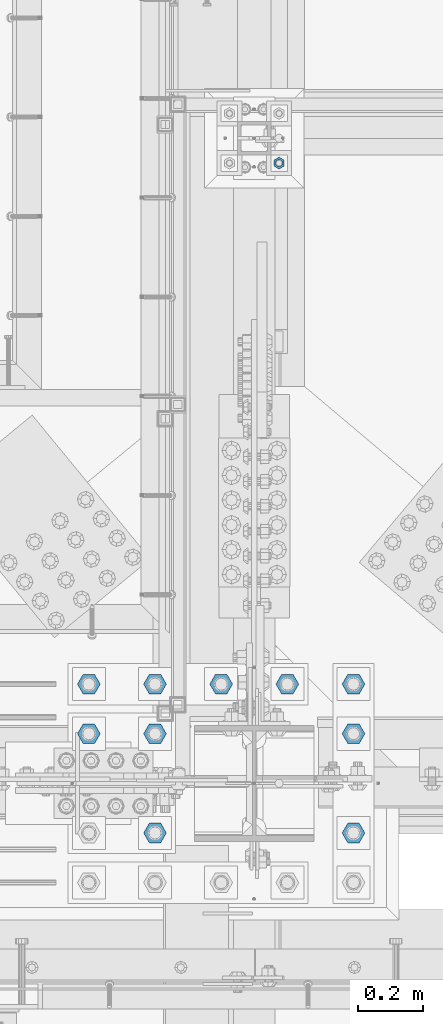
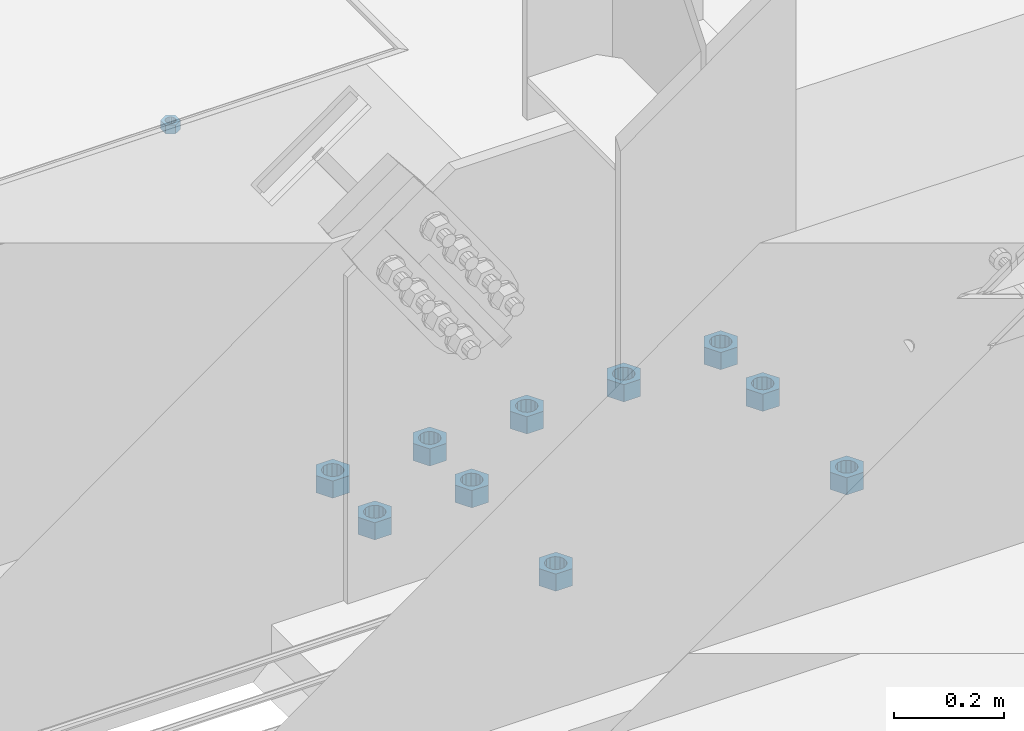
# One storey, part 1663 of 3843: 11 columns, 2 elements without a shape of their own.
"""IFC2X3 building model written with IfcOpenShell, lengths in millimetres."""

from ifc_helpers import new_model, si_unit, frame, origin_with_axes, place, context, subcontext, project, spatial, faceted_brep, material, type_object, element, aggregate, save


model = new_model("IFC2X3")

# Units and contexts
model_context = context("Model", 3, precision=1e-05, world=origin_with_axes())
body_context = subcontext(model_context, "Body", "Model", "MODEL_VIEW")
ifc_project = project(units=[si_unit("LENGTHUNIT", "METRE", prefix="MILLI"), si_unit("AREAUNIT", "SQUARE_METRE"), si_unit("VOLUMEUNIT", "CUBIC_METRE"), si_unit("MASSUNIT", "GRAM", prefix="KILO"), si_unit("TIMEUNIT", "SECOND"), si_unit("PLANEANGLEUNIT", "RADIAN"), si_unit("SOLIDANGLEUNIT", "STERADIAN"), si_unit("THERMODYNAMICTEMPERATUREUNIT", "DEGREE_CELSIUS"), si_unit("LUMINOUSINTENSITYUNIT", "LUMEN")], contexts=[model_context])

# Site, building, storey
site_placement = place(None, origin_with_axes())
site = spatial("IfcSite", under=ifc_project, at=site_placement, CompositionType="ELEMENT")
building_placement = place(site_placement, origin_with_axes())
building = spatial("IfcBuilding", under=site, at=building_placement, Name="Undefined", CompositionType="ELEMENT")
storey_placement = place(building_placement, origin_with_axes())
storey = spatial("IfcBuildingStorey", under=building, at=storey_placement, Name="Undefined", CompositionType="ELEMENT", Elevation=0.0)

# Assembly, column
assembly_1_placement = place(storey_placement, origin_with_axes())
assembly_1 = element("IfcElementAssembly", 1, at=assembly_1_placement, inside=storey, Name="TEMPLATE", AssemblyPlace="NOTDEFINED", PredefinedType="RIGID_FRAME")
ifc_material_1 = material(Name="STEEL/A36")
column_type_1 = type_object("IfcColumnType", Name="3/4_HEAVY_HEX_NUT", PredefinedType="NOTDEFINED")
column_1_placement = place(assembly_1_placement, frame((49072.8, 27520.9, 29330.65), z_axis=(1.0, 0.0, 0.0), x_axis=(0.0, 0.0, -1.0)))
column_1 = element("IfcColumn", 2, at=column_1_placement, type_object=column_type_1, material=ifc_material_1, Name="NUT", ObjectType="3/4_HEAVY_HEX_NUT", context=body_context, shape_type="Brep", body=[
    faceted_brep([(0.0, -18.2600002288818, 0.0), (0.0, -9.13000011444092, -15.8100004196167), (19.0500000000029, -9.13000011444092, -15.8100004196167), (19.0500000000029, -18.2600002288818, 0.0), (0.0, 9.13000011444092, -15.8100004196167), (19.0500000000029, 9.13000011444092, -15.8100004196167), (0.0, 18.2600002288818, 0.0), (19.0500000000029, 18.2600002288818, 0.0), (0.0, 9.13000011444092, 15.8100004196167), (19.0500000000029, 9.13000011444092, 15.8100004196167), (0.0, -9.13000011444092, 15.8100004196167), (19.0500000000029, -9.13000011444092, 15.8100004196167), (0.0, 0.0, 10.3199996948242), (0.0, 4.47768005527905, 9.29799844179797), (19.0500000000029, 4.47768005527905, 9.29799844179797), (19.0500000000029, 0.0, 10.3199996948242), (0.0, 8.06850066047627, 6.43441456490837), (19.0500000000029, 8.06850066047627, 6.43441456490837), (0.0, 10.0612557561908, 2.2964159705225), (19.0500000000029, 10.0612557561908, 2.2964159705225), (0.0, 10.0612557561908, -2.2964159705225), (19.0500000000029, 10.0612557561908, -2.2964159705225), (0.0, 8.06850066047627, -6.43441456490837), (19.0500000000029, 8.06850066047627, -6.43441456490837), (0.0, 4.47768005527905, -9.29799844179797), (19.0500000000029, 4.47768005527905, -9.29799844179797), (0.0, 0.0, -10.3199996948242), (19.0500000000029, 0.0, -10.3199996948242), (0.0, -4.47768005527905, -9.29799844179797), (19.0500000000029, -4.47768005527905, -9.29799844179797), (0.0, -8.06850066047627, -6.43441456490837), (19.0500000000029, -8.06850066047627, -6.43441456490837), (0.0, -10.0612557561908, -2.2964159705225), (19.0500000000029, -10.0612557561908, -2.2964159705225), (0.0, -10.0612557561908, 2.2964159705225), (19.0500000000029, -10.0612557561908, 2.2964159705225), (0.0, -8.06850066047627, 6.43441456490837), (19.0500000000029, -8.06850066047627, 6.43441456490837), (0.0, -4.47768005527905, 9.29799844179797), (19.0500000000029, -4.47768005527905, 9.29799844179797)], [[[0, 1, 2, 3]], [[1, 4, 5, 2]], [[4, 6, 7, 5]], [[6, 8, 9, 7]], [[8, 10, 11, 9]], [[10, 0, 3, 11]], [[12, 13, 14, 15]], [[13, 16, 17, 14]], [[16, 18, 19, 17]], [[18, 20, 21, 19]], [[20, 22, 23, 21]], [[22, 24, 25, 23]], [[24, 26, 27, 25]], [[26, 28, 29, 27]], [[28, 30, 31, 29]], [[30, 32, 33, 31]], [[32, 34, 35, 33]], [[34, 36, 37, 35]], [[36, 38, 39, 37]], [[38, 12, 15, 39]], [[5, 7, 9, 11, 3, 2], [17, 19, 21, 23, 25, 27, 29, 31, 33, 35, 37, 39, 15, 14]], [[10, 8, 6, 4, 1, 0], [38, 36, 34, 32, 30, 28, 26, 24, 22, 20, 18, 16, 13, 12]]]),
])
aggregate(assembly_1, [column_1])

# Assembly, columns
assembly_2_placement = place(storey_placement, origin_with_axes())
assembly_2 = element("IfcElementAssembly", 3, at=assembly_2_placement, inside=storey, Name="TEMPLATE", AssemblyPlace="NOTDEFINED", PredefinedType="RIGID_FRAME")
ifc_material_2 = material(Name="STEEL/A572-50")
column_type_2 = type_object("IfcColumnType", Name="1-1/2_HEAVY_HEX_NUT", PredefinedType="NOTDEFINED")
column_2_placement = place(assembly_2_placement, frame((48691.8, 25463.5, 29730.7), z_axis=(0.0, -1.0, 0.0), x_axis=(0.0, 0.0, -1.0)))
column_2 = element("IfcColumn", 4, at=column_2_placement, type_object=column_type_2, material=ifc_material_2, Name="NUT", ObjectType="1-1/2_HEAVY_HEX_NUT", context=body_context, shape_type="Brep", body=[
    faceted_brep([(0.0, -34.9199981689453, 0.0), (0.0, -17.4599990844727, -30.25), (38.0999999999985, -17.4599990844727, -30.25), (38.0999999999985, -34.9199981689453, 0.0), (0.0, 17.4599990844727, -30.25), (38.0999999999985, 17.4599990844727, -30.25), (0.0, 34.9199981689453, 0.0), (38.0999999999985, 34.9199981689453, 0.0), (0.0, 17.4599990844727, 30.25), (38.0999999999985, 17.4599990844727, 30.25), (0.0, -17.4599990844727, 30.25), (38.0999999999985, -17.4599990844727, 30.25), (0.0, 0.0, 20.6399993896484), (0.0, 8.9553601105581, 18.5959968835959), (38.0999999999985, 8.9553601105581, 18.5959968835959), (38.0999999999985, 0.0, 20.6399993896484), (0.0, 16.1370013209525, 12.8688291298167), (38.0999999999985, 16.1370013209525, 12.8688291298167), (0.0, 20.1225115123816, 4.59283194104501), (38.0999999999985, 20.1225115123816, 4.59283194104501), (0.0, 20.1225115123816, -4.59283194104501), (38.0999999999985, 20.1225115123816, -4.59283194104501), (0.0, 16.1370013209525, -12.8688291298167), (38.0999999999985, 16.1370013209525, -12.8688291298167), (0.0, 8.9553601105581, -18.5959968835959), (38.0999999999985, 8.9553601105581, -18.5959968835959), (0.0, 0.0, -20.6399993896484), (38.0999999999985, 0.0, -20.6399993896484), (0.0, -8.9553601105581, -18.5959968835959), (38.0999999999985, -8.9553601105581, -18.5959968835959), (0.0, -16.1370013209525, -12.8688291298167), (38.0999999999985, -16.1370013209525, -12.8688291298167), (0.0, -20.1225115123816, -4.59283194104501), (38.0999999999985, -20.1225115123816, -4.59283194104501), (0.0, -20.1225115123816, 4.59283194104501), (38.0999999999985, -20.1225115123816, 4.59283194104501), (0.0, -16.1370013209525, 12.8688291298167), (38.0999999999985, -16.1370013209525, 12.8688291298167), (0.0, -8.9553601105581, 18.5959968835959), (38.0999999999985, -8.9553601105581, 18.5959968835959)], [[[0, 1, 2, 3]], [[1, 4, 5, 2]], [[4, 6, 7, 5]], [[6, 8, 9, 7]], [[8, 10, 11, 9]], [[10, 0, 3, 11]], [[12, 13, 14, 15]], [[13, 16, 17, 14]], [[16, 18, 19, 17]], [[18, 20, 21, 19]], [[20, 22, 23, 21]], [[22, 24, 25, 23]], [[24, 26, 27, 25]], [[26, 28, 29, 27]], [[28, 30, 31, 29]], [[30, 32, 33, 31]], [[32, 34, 35, 33]], [[34, 36, 37, 35]], [[36, 38, 39, 37]], [[38, 12, 15, 39]], [[5, 7, 9, 11, 3, 2], [17, 19, 21, 23, 25, 27, 29, 31, 33, 35, 37, 39, 15, 14]], [[10, 8, 6, 4, 1, 0], [38, 36, 34, 32, 30, 28, 26, 24, 22, 20, 18, 16, 13, 12]]]),
])
column_3_placement = place(assembly_2_placement, frame((49301.4, 25463.5, 29730.7), z_axis=(0.0, 1.0, 0.0), x_axis=(0.0, 0.0, -1.0)))
column_3 = element("IfcColumn", 5, at=column_3_placement, type_object=column_type_2, material=ifc_material_2, Name="NUT", ObjectType="1-1/2_HEAVY_HEX_NUT", context=body_context, shape_type="Brep", body=[
    faceted_brep([(0.0, -34.9199981689453, 0.0), (0.0, -17.4599990844727, -30.25), (38.0999999999985, -17.4599990844727, -30.25), (38.0999999999985, -34.9199981689453, 0.0), (0.0, 17.4599990844727, -30.25), (38.0999999999985, 17.4599990844727, -30.25), (0.0, 34.9199981689453, 0.0), (38.0999999999985, 34.9199981689453, 0.0), (0.0, 17.4599990844727, 30.25), (38.0999999999985, 17.4599990844727, 30.25), (0.0, -17.4599990844727, 30.25), (38.0999999999985, -17.4599990844727, 30.25), (0.0, 0.0, 20.6399993896484), (0.0, 8.9553601105581, 18.5959968835959), (38.0999999999985, 8.9553601105581, 18.5959968835959), (38.0999999999985, 0.0, 20.6399993896484), (0.0, 16.1370013209525, 12.8688291298167), (38.0999999999985, 16.1370013209525, 12.8688291298167), (0.0, 20.1225115123816, 4.59283194104501), (38.0999999999985, 20.1225115123816, 4.59283194104501), (0.0, 20.1225115123816, -4.59283194104501), (38.0999999999985, 20.1225115123816, -4.59283194104501), (0.0, 16.1370013209525, -12.8688291298167), (38.0999999999985, 16.1370013209525, -12.8688291298167), (0.0, 8.9553601105581, -18.5959968835959), (38.0999999999985, 8.9553601105581, -18.5959968835959), (0.0, 0.0, -20.6399993896484), (38.0999999999985, 0.0, -20.6399993896484), (0.0, -8.9553601105581, -18.5959968835959), (38.0999999999985, -8.9553601105581, -18.5959968835959), (0.0, -16.1370013209525, -12.8688291298167), (38.0999999999985, -16.1370013209525, -12.8688291298167), (0.0, -20.1225115123816, -4.59283194104501), (38.0999999999985, -20.1225115123816, -4.59283194104501), (0.0, -20.1225115123816, 4.59283194104501), (38.0999999999985, -20.1225115123816, 4.59283194104501), (0.0, -16.1370013209525, 12.8688291298167), (38.0999999999985, -16.1370013209525, 12.8688291298167), (0.0, -8.9553601105581, 18.5959968835959), (38.0999999999985, -8.9553601105581, 18.5959968835959)], [[[0, 1, 2, 3]], [[1, 4, 5, 2]], [[4, 6, 7, 5]], [[6, 8, 9, 7]], [[8, 10, 11, 9]], [[10, 0, 3, 11]], [[12, 13, 14, 15]], [[13, 16, 17, 14]], [[16, 18, 19, 17]], [[18, 20, 21, 19]], [[20, 22, 23, 21]], [[22, 24, 25, 23]], [[24, 26, 27, 25]], [[26, 28, 29, 27]], [[28, 30, 31, 29]], [[30, 32, 33, 31]], [[32, 34, 35, 33]], [[34, 36, 37, 35]], [[36, 38, 39, 37]], [[38, 12, 15, 39]], [[5, 7, 9, 11, 3, 2], [17, 19, 21, 23, 25, 27, 29, 31, 33, 35, 37, 39, 15, 14]], [[10, 8, 6, 4, 1, 0], [38, 36, 34, 32, 30, 28, 26, 24, 22, 20, 18, 16, 13, 12]]]),
])
column_4_placement = place(assembly_2_placement, frame((48488.6, 25768.3, 29730.7), z_axis=(0.0, -1.0, 0.0), x_axis=(0.0, 0.0, -1.0)))
column_4 = element("IfcColumn", 6, at=column_4_placement, type_object=column_type_2, material=ifc_material_2, Name="NUT", ObjectType="1-1/2_HEAVY_HEX_NUT", context=body_context, shape_type="Brep", body=[
    faceted_brep([(0.0, -34.9199981689453, 0.0), (0.0, -17.4599990844727, -30.25), (38.0999999999985, -17.4599990844727, -30.25), (38.0999999999985, -34.9199981689453, 0.0), (0.0, 17.4599990844727, -30.25), (38.0999999999985, 17.4599990844727, -30.25), (0.0, 34.9199981689453, 0.0), (38.0999999999985, 34.9199981689453, 0.0), (0.0, 17.4599990844727, 30.25), (38.0999999999985, 17.4599990844727, 30.25), (0.0, -17.4599990844727, 30.25), (38.0999999999985, -17.4599990844727, 30.25), (0.0, 0.0, 20.6399993896484), (0.0, 8.9553601105581, 18.5959968835959), (38.0999999999985, 8.9553601105581, 18.5959968835959), (38.0999999999985, 0.0, 20.6399993896484), (0.0, 16.1370013209525, 12.8688291298167), (38.0999999999985, 16.1370013209525, 12.8688291298167), (0.0, 20.1225115123816, 4.59283194104501), (38.0999999999985, 20.1225115123816, 4.59283194104501), (0.0, 20.1225115123816, -4.59283194104501), (38.0999999999985, 20.1225115123816, -4.59283194104501), (0.0, 16.1370013209525, -12.8688291298167), (38.0999999999985, 16.1370013209525, -12.8688291298167), (0.0, 8.9553601105581, -18.5959968835959), (38.0999999999985, 8.9553601105581, -18.5959968835959), (0.0, 0.0, -20.6399993896484), (38.0999999999985, 0.0, -20.6399993896484), (0.0, -8.9553601105581, -18.5959968835959), (38.0999999999985, -8.9553601105581, -18.5959968835959), (0.0, -16.1370013209525, -12.8688291298167), (38.0999999999985, -16.1370013209525, -12.8688291298167), (0.0, -20.1225115123816, -4.59283194104501), (38.0999999999985, -20.1225115123816, -4.59283194104501), (0.0, -20.1225115123816, 4.59283194104501), (38.0999999999985, -20.1225115123816, 4.59283194104501), (0.0, -16.1370013209525, 12.8688291298167), (38.0999999999985, -16.1370013209525, 12.8688291298167), (0.0, -8.9553601105581, 18.5959968835959), (38.0999999999985, -8.9553601105581, 18.5959968835959)], [[[0, 1, 2, 3]], [[1, 4, 5, 2]], [[4, 6, 7, 5]], [[6, 8, 9, 7]], [[8, 10, 11, 9]], [[10, 0, 3, 11]], [[12, 13, 14, 15]], [[13, 16, 17, 14]], [[16, 18, 19, 17]], [[18, 20, 21, 19]], [[20, 22, 23, 21]], [[22, 24, 25, 23]], [[24, 26, 27, 25]], [[26, 28, 29, 27]], [[28, 30, 31, 29]], [[30, 32, 33, 31]], [[32, 34, 35, 33]], [[34, 36, 37, 35]], [[36, 38, 39, 37]], [[38, 12, 15, 39]], [[5, 7, 9, 11, 3, 2], [17, 19, 21, 23, 25, 27, 29, 31, 33, 35, 37, 39, 15, 14]], [[10, 8, 6, 4, 1, 0], [38, 36, 34, 32, 30, 28, 26, 24, 22, 20, 18, 16, 13, 12]]]),
])
column_5_placement = place(assembly_2_placement, frame((48691.8, 25768.3, 29730.7), z_axis=(0.0, -1.0, 0.0), x_axis=(0.0, 0.0, -1.0)))
column_5 = element("IfcColumn", 7, at=column_5_placement, type_object=column_type_2, material=ifc_material_2, Name="NUT", ObjectType="1-1/2_HEAVY_HEX_NUT", context=body_context, shape_type="Brep", body=[
    faceted_brep([(0.0, -34.9199981689453, 0.0), (0.0, -17.4599990844727, -30.25), (38.0999999999985, -17.4599990844727, -30.25), (38.0999999999985, -34.9199981689453, 0.0), (0.0, 17.4599990844727, -30.25), (38.0999999999985, 17.4599990844727, -30.25), (0.0, 34.9199981689453, 0.0), (38.0999999999985, 34.9199981689453, 0.0), (0.0, 17.4599990844727, 30.25), (38.0999999999985, 17.4599990844727, 30.25), (0.0, -17.4599990844727, 30.25), (38.0999999999985, -17.4599990844727, 30.25), (0.0, 0.0, 20.6399993896484), (0.0, 8.9553601105581, 18.5959968835959), (38.0999999999985, 8.9553601105581, 18.5959968835959), (38.0999999999985, 0.0, 20.6399993896484), (0.0, 16.1370013209525, 12.8688291298167), (38.0999999999985, 16.1370013209525, 12.8688291298167), (0.0, 20.1225115123816, 4.59283194104501), (38.0999999999985, 20.1225115123816, 4.59283194104501), (0.0, 20.1225115123816, -4.59283194104501), (38.0999999999985, 20.1225115123816, -4.59283194104501), (0.0, 16.1370013209525, -12.8688291298167), (38.0999999999985, 16.1370013209525, -12.8688291298167), (0.0, 8.9553601105581, -18.5959968835959), (38.0999999999985, 8.9553601105581, -18.5959968835959), (0.0, 0.0, -20.6399993896484), (38.0999999999985, 0.0, -20.6399993896484), (0.0, -8.9553601105581, -18.5959968835959), (38.0999999999985, -8.9553601105581, -18.5959968835959), (0.0, -16.1370013209525, -12.8688291298167), (38.0999999999985, -16.1370013209525, -12.8688291298167), (0.0, -20.1225115123816, -4.59283194104501), (38.0999999999985, -20.1225115123816, -4.59283194104501), (0.0, -20.1225115123816, 4.59283194104501), (38.0999999999985, -20.1225115123816, 4.59283194104501), (0.0, -16.1370013209525, 12.8688291298167), (38.0999999999985, -16.1370013209525, 12.8688291298167), (0.0, -8.9553601105581, 18.5959968835959), (38.0999999999985, -8.9553601105581, 18.5959968835959)], [[[0, 1, 2, 3]], [[1, 4, 5, 2]], [[4, 6, 7, 5]], [[6, 8, 9, 7]], [[8, 10, 11, 9]], [[10, 0, 3, 11]], [[12, 13, 14, 15]], [[13, 16, 17, 14]], [[16, 18, 19, 17]], [[18, 20, 21, 19]], [[20, 22, 23, 21]], [[22, 24, 25, 23]], [[24, 26, 27, 25]], [[26, 28, 29, 27]], [[28, 30, 31, 29]], [[30, 32, 33, 31]], [[32, 34, 35, 33]], [[34, 36, 37, 35]], [[36, 38, 39, 37]], [[38, 12, 15, 39]], [[5, 7, 9, 11, 3, 2], [17, 19, 21, 23, 25, 27, 29, 31, 33, 35, 37, 39, 15, 14]], [[10, 8, 6, 4, 1, 0], [38, 36, 34, 32, 30, 28, 26, 24, 22, 20, 18, 16, 13, 12]]]),
])
column_6_placement = place(assembly_2_placement, frame((49301.4, 25768.3, 29730.7), z_axis=(0.0, 1.0, 0.0), x_axis=(0.0, 0.0, -1.0)))
column_6 = element("IfcColumn", 8, at=column_6_placement, type_object=column_type_2, material=ifc_material_2, Name="NUT", ObjectType="1-1/2_HEAVY_HEX_NUT", context=body_context, shape_type="Brep", body=[
    faceted_brep([(0.0, -34.9199981689453, 0.0), (0.0, -17.4599990844727, -30.25), (38.0999999999985, -17.4599990844727, -30.25), (38.0999999999985, -34.9199981689453, 0.0), (0.0, 17.4599990844727, -30.25), (38.0999999999985, 17.4599990844727, -30.25), (0.0, 34.9199981689453, 0.0), (38.0999999999985, 34.9199981689453, 0.0), (0.0, 17.4599990844727, 30.25), (38.0999999999985, 17.4599990844727, 30.25), (0.0, -17.4599990844727, 30.25), (38.0999999999985, -17.4599990844727, 30.25), (0.0, 0.0, 20.6399993896484), (0.0, 8.9553601105581, 18.5959968835959), (38.0999999999985, 8.9553601105581, 18.5959968835959), (38.0999999999985, 0.0, 20.6399993896484), (0.0, 16.1370013209525, 12.8688291298167), (38.0999999999985, 16.1370013209525, 12.8688291298167), (0.0, 20.1225115123816, 4.59283194104501), (38.0999999999985, 20.1225115123816, 4.59283194104501), (0.0, 20.1225115123816, -4.59283194104501), (38.0999999999985, 20.1225115123816, -4.59283194104501), (0.0, 16.1370013209525, -12.8688291298167), (38.0999999999985, 16.1370013209525, -12.8688291298167), (0.0, 8.9553601105581, -18.5959968835959), (38.0999999999985, 8.9553601105581, -18.5959968835959), (0.0, 0.0, -20.6399993896484), (38.0999999999985, 0.0, -20.6399993896484), (0.0, -8.9553601105581, -18.5959968835959), (38.0999999999985, -8.9553601105581, -18.5959968835959), (0.0, -16.1370013209525, -12.8688291298167), (38.0999999999985, -16.1370013209525, -12.8688291298167), (0.0, -20.1225115123816, -4.59283194104501), (38.0999999999985, -20.1225115123816, -4.59283194104501), (0.0, -20.1225115123816, 4.59283194104501), (38.0999999999985, -20.1225115123816, 4.59283194104501), (0.0, -16.1370013209525, 12.8688291298167), (38.0999999999985, -16.1370013209525, 12.8688291298167), (0.0, -8.9553601105581, 18.5959968835959), (38.0999999999985, -8.9553601105581, 18.5959968835959)], [[[0, 1, 2, 3]], [[1, 4, 5, 2]], [[4, 6, 7, 5]], [[6, 8, 9, 7]], [[8, 10, 11, 9]], [[10, 0, 3, 11]], [[12, 13, 14, 15]], [[13, 16, 17, 14]], [[16, 18, 19, 17]], [[18, 20, 21, 19]], [[20, 22, 23, 21]], [[22, 24, 25, 23]], [[24, 26, 27, 25]], [[26, 28, 29, 27]], [[28, 30, 31, 29]], [[30, 32, 33, 31]], [[32, 34, 35, 33]], [[34, 36, 37, 35]], [[36, 38, 39, 37]], [[38, 12, 15, 39]], [[5, 7, 9, 11, 3, 2], [17, 19, 21, 23, 25, 27, 29, 31, 33, 35, 37, 39, 15, 14]], [[10, 8, 6, 4, 1, 0], [38, 36, 34, 32, 30, 28, 26, 24, 22, 20, 18, 16, 13, 12]]]),
])
column_7_placement = place(assembly_2_placement, frame((48488.6, 25920.7, 29730.7), z_axis=(0.0, -1.0, 0.0), x_axis=(0.0, 0.0, -1.0)))
column_7 = element("IfcColumn", 9, at=column_7_placement, type_object=column_type_2, material=ifc_material_2, Name="NUT", ObjectType="1-1/2_HEAVY_HEX_NUT", context=body_context, shape_type="Brep", body=[
    faceted_brep([(0.0, -34.9199981689453, 0.0), (0.0, -17.4599990844727, -30.25), (38.0999999999985, -17.4599990844727, -30.25), (38.0999999999985, -34.9199981689453, 0.0), (0.0, 17.4599990844727, -30.25), (38.0999999999985, 17.4599990844727, -30.25), (0.0, 34.9199981689453, 0.0), (38.0999999999985, 34.9199981689453, 0.0), (0.0, 17.4599990844727, 30.25), (38.0999999999985, 17.4599990844727, 30.25), (0.0, -17.4599990844727, 30.25), (38.0999999999985, -17.4599990844727, 30.25), (0.0, 0.0, 20.6399993896484), (0.0, 8.9553601105581, 18.5959968835959), (38.0999999999985, 8.9553601105581, 18.5959968835959), (38.0999999999985, 0.0, 20.6399993896484), (0.0, 16.1370013209525, 12.8688291298167), (38.0999999999985, 16.1370013209525, 12.8688291298167), (0.0, 20.1225115123816, 4.59283194104501), (38.0999999999985, 20.1225115123816, 4.59283194104501), (0.0, 20.1225115123816, -4.59283194104501), (38.0999999999985, 20.1225115123816, -4.59283194104501), (0.0, 16.1370013209525, -12.8688291298167), (38.0999999999985, 16.1370013209525, -12.8688291298167), (0.0, 8.9553601105581, -18.5959968835959), (38.0999999999985, 8.9553601105581, -18.5959968835959), (0.0, 0.0, -20.6399993896484), (38.0999999999985, 0.0, -20.6399993896484), (0.0, -8.9553601105581, -18.5959968835959), (38.0999999999985, -8.9553601105581, -18.5959968835959), (0.0, -16.1370013209525, -12.8688291298167), (38.0999999999985, -16.1370013209525, -12.8688291298167), (0.0, -20.1225115123816, -4.59283194104501), (38.0999999999985, -20.1225115123816, -4.59283194104501), (0.0, -20.1225115123816, 4.59283194104501), (38.0999999999985, -20.1225115123816, 4.59283194104501), (0.0, -16.1370013209525, 12.8688291298167), (38.0999999999985, -16.1370013209525, 12.8688291298167), (0.0, -8.9553601105581, 18.5959968835959), (38.0999999999985, -8.9553601105581, 18.5959968835959)], [[[0, 1, 2, 3]], [[1, 4, 5, 2]], [[4, 6, 7, 5]], [[6, 8, 9, 7]], [[8, 10, 11, 9]], [[10, 0, 3, 11]], [[12, 13, 14, 15]], [[13, 16, 17, 14]], [[16, 18, 19, 17]], [[18, 20, 21, 19]], [[20, 22, 23, 21]], [[22, 24, 25, 23]], [[24, 26, 27, 25]], [[26, 28, 29, 27]], [[28, 30, 31, 29]], [[30, 32, 33, 31]], [[32, 34, 35, 33]], [[34, 36, 37, 35]], [[36, 38, 39, 37]], [[38, 12, 15, 39]], [[5, 7, 9, 11, 3, 2], [17, 19, 21, 23, 25, 27, 29, 31, 33, 35, 37, 39, 15, 14]], [[10, 8, 6, 4, 1, 0], [38, 36, 34, 32, 30, 28, 26, 24, 22, 20, 18, 16, 13, 12]]]),
])
column_8_placement = place(assembly_2_placement, frame((48691.8, 25920.7, 29730.7), z_axis=(0.0, -1.0, 0.0), x_axis=(0.0, 0.0, -1.0)))
column_8 = element("IfcColumn", 10, at=column_8_placement, type_object=column_type_2, material=ifc_material_2, Name="NUT", ObjectType="1-1/2_HEAVY_HEX_NUT", context=body_context, shape_type="Brep", body=[
    faceted_brep([(0.0, -34.9199981689453, 0.0), (0.0, -17.4599990844727, -30.25), (38.0999999999985, -17.4599990844727, -30.25), (38.0999999999985, -34.9199981689453, 0.0), (0.0, 17.4599990844727, -30.25), (38.0999999999985, 17.4599990844727, -30.25), (0.0, 34.9199981689453, 0.0), (38.0999999999985, 34.9199981689453, 0.0), (0.0, 17.4599990844727, 30.25), (38.0999999999985, 17.4599990844727, 30.25), (0.0, -17.4599990844727, 30.25), (38.0999999999985, -17.4599990844727, 30.25), (0.0, 0.0, 20.6399993896484), (0.0, 8.9553601105581, 18.5959968835959), (38.0999999999985, 8.9553601105581, 18.5959968835959), (38.0999999999985, 0.0, 20.6399993896484), (0.0, 16.1370013209525, 12.8688291298167), (38.0999999999985, 16.1370013209525, 12.8688291298167), (0.0, 20.1225115123816, 4.59283194104501), (38.0999999999985, 20.1225115123816, 4.59283194104501), (0.0, 20.1225115123816, -4.59283194104501), (38.0999999999985, 20.1225115123816, -4.59283194104501), (0.0, 16.1370013209525, -12.8688291298167), (38.0999999999985, 16.1370013209525, -12.8688291298167), (0.0, 8.9553601105581, -18.5959968835959), (38.0999999999985, 8.9553601105581, -18.5959968835959), (0.0, 0.0, -20.6399993896484), (38.0999999999985, 0.0, -20.6399993896484), (0.0, -8.9553601105581, -18.5959968835959), (38.0999999999985, -8.9553601105581, -18.5959968835959), (0.0, -16.1370013209525, -12.8688291298167), (38.0999999999985, -16.1370013209525, -12.8688291298167), (0.0, -20.1225115123816, -4.59283194104501), (38.0999999999985, -20.1225115123816, -4.59283194104501), (0.0, -20.1225115123816, 4.59283194104501), (38.0999999999985, -20.1225115123816, 4.59283194104501), (0.0, -16.1370013209525, 12.8688291298167), (38.0999999999985, -16.1370013209525, 12.8688291298167), (0.0, -8.9553601105581, 18.5959968835959), (38.0999999999985, -8.9553601105581, 18.5959968835959)], [[[0, 1, 2, 3]], [[1, 4, 5, 2]], [[4, 6, 7, 5]], [[6, 8, 9, 7]], [[8, 10, 11, 9]], [[10, 0, 3, 11]], [[12, 13, 14, 15]], [[13, 16, 17, 14]], [[16, 18, 19, 17]], [[18, 20, 21, 19]], [[20, 22, 23, 21]], [[22, 24, 25, 23]], [[24, 26, 27, 25]], [[26, 28, 29, 27]], [[28, 30, 31, 29]], [[30, 32, 33, 31]], [[32, 34, 35, 33]], [[34, 36, 37, 35]], [[36, 38, 39, 37]], [[38, 12, 15, 39]], [[5, 7, 9, 11, 3, 2], [17, 19, 21, 23, 25, 27, 29, 31, 33, 35, 37, 39, 15, 14]], [[10, 8, 6, 4, 1, 0], [38, 36, 34, 32, 30, 28, 26, 24, 22, 20, 18, 16, 13, 12]]]),
])
column_9_placement = place(assembly_2_placement, frame((48895.0, 25920.7, 29730.7), z_axis=(0.0, -1.0, 0.0), x_axis=(0.0, 0.0, -1.0)))
column_9 = element("IfcColumn", 11, at=column_9_placement, type_object=column_type_2, material=ifc_material_2, Name="NUT", ObjectType="1-1/2_HEAVY_HEX_NUT", context=body_context, shape_type="Brep", body=[
    faceted_brep([(0.0, -34.9199981689453, 0.0), (0.0, -17.4599990844727, -30.25), (38.0999999999985, -17.4599990844727, -30.25), (38.0999999999985, -34.9199981689453, 0.0), (0.0, 17.4599990844727, -30.25), (38.0999999999985, 17.4599990844727, -30.25), (0.0, 34.9199981689453, 0.0), (38.0999999999985, 34.9199981689453, 0.0), (0.0, 17.4599990844727, 30.25), (38.0999999999985, 17.4599990844727, 30.25), (0.0, -17.4599990844727, 30.25), (38.0999999999985, -17.4599990844727, 30.25), (0.0, 0.0, 20.6399993896484), (0.0, 8.9553601105581, 18.5959968835959), (38.0999999999985, 8.9553601105581, 18.5959968835959), (38.0999999999985, 0.0, 20.6399993896484), (0.0, 16.1370013209525, 12.8688291298167), (38.0999999999985, 16.1370013209525, 12.8688291298167), (0.0, 20.1225115123816, 4.59283194104501), (38.0999999999985, 20.1225115123816, 4.59283194104501), (0.0, 20.1225115123816, -4.59283194104501), (38.0999999999985, 20.1225115123816, -4.59283194104501), (0.0, 16.1370013209525, -12.8688291298167), (38.0999999999985, 16.1370013209525, -12.8688291298167), (0.0, 8.9553601105581, -18.5959968835959), (38.0999999999985, 8.9553601105581, -18.5959968835959), (0.0, 0.0, -20.6399993896484), (38.0999999999985, 0.0, -20.6399993896484), (0.0, -8.9553601105581, -18.5959968835959), (38.0999999999985, -8.9553601105581, -18.5959968835959), (0.0, -16.1370013209525, -12.8688291298167), (38.0999999999985, -16.1370013209525, -12.8688291298167), (0.0, -20.1225115123816, -4.59283194104501), (38.0999999999985, -20.1225115123816, -4.59283194104501), (0.0, -20.1225115123816, 4.59283194104501), (38.0999999999985, -20.1225115123816, 4.59283194104501), (0.0, -16.1370013209525, 12.8688291298167), (38.0999999999985, -16.1370013209525, 12.8688291298167), (0.0, -8.9553601105581, 18.5959968835959), (38.0999999999985, -8.9553601105581, 18.5959968835959)], [[[0, 1, 2, 3]], [[1, 4, 5, 2]], [[4, 6, 7, 5]], [[6, 8, 9, 7]], [[8, 10, 11, 9]], [[10, 0, 3, 11]], [[12, 13, 14, 15]], [[13, 16, 17, 14]], [[16, 18, 19, 17]], [[18, 20, 21, 19]], [[20, 22, 23, 21]], [[22, 24, 25, 23]], [[24, 26, 27, 25]], [[26, 28, 29, 27]], [[28, 30, 31, 29]], [[30, 32, 33, 31]], [[32, 34, 35, 33]], [[34, 36, 37, 35]], [[36, 38, 39, 37]], [[38, 12, 15, 39]], [[5, 7, 9, 11, 3, 2], [17, 19, 21, 23, 25, 27, 29, 31, 33, 35, 37, 39, 15, 14]], [[10, 8, 6, 4, 1, 0], [38, 36, 34, 32, 30, 28, 26, 24, 22, 20, 18, 16, 13, 12]]]),
])
column_10_placement = place(assembly_2_placement, frame((49098.2, 25920.7, 29730.7), z_axis=(0.0, 1.0, 0.0), x_axis=(0.0, 0.0, -1.0)))
column_10 = element("IfcColumn", 12, at=column_10_placement, type_object=column_type_2, material=ifc_material_2, Name="NUT", ObjectType="1-1/2_HEAVY_HEX_NUT", context=body_context, shape_type="Brep", body=[
    faceted_brep([(0.0, -34.9199981689453, 0.0), (0.0, -17.4599990844727, -30.25), (38.0999999999985, -17.4599990844727, -30.25), (38.0999999999985, -34.9199981689453, 0.0), (0.0, 17.4599990844727, -30.25), (38.0999999999985, 17.4599990844727, -30.25), (0.0, 34.9199981689453, 0.0), (38.0999999999985, 34.9199981689453, 0.0), (0.0, 17.4599990844727, 30.25), (38.0999999999985, 17.4599990844727, 30.25), (0.0, -17.4599990844727, 30.25), (38.0999999999985, -17.4599990844727, 30.25), (0.0, 0.0, 20.6399993896484), (0.0, 8.9553601105581, 18.5959968835959), (38.0999999999985, 8.9553601105581, 18.5959968835959), (38.0999999999985, 0.0, 20.6399993896484), (0.0, 16.1370013209525, 12.8688291298167), (38.0999999999985, 16.1370013209525, 12.8688291298167), (0.0, 20.1225115123816, 4.59283194104501), (38.0999999999985, 20.1225115123816, 4.59283194104501), (0.0, 20.1225115123816, -4.59283194104501), (38.0999999999985, 20.1225115123816, -4.59283194104501), (0.0, 16.1370013209525, -12.8688291298167), (38.0999999999985, 16.1370013209525, -12.8688291298167), (0.0, 8.9553601105581, -18.5959968835959), (38.0999999999985, 8.9553601105581, -18.5959968835959), (0.0, 0.0, -20.6399993896484), (38.0999999999985, 0.0, -20.6399993896484), (0.0, -8.9553601105581, -18.5959968835959), (38.0999999999985, -8.9553601105581, -18.5959968835959), (0.0, -16.1370013209525, -12.8688291298167), (38.0999999999985, -16.1370013209525, -12.8688291298167), (0.0, -20.1225115123816, -4.59283194104501), (38.0999999999985, -20.1225115123816, -4.59283194104501), (0.0, -20.1225115123816, 4.59283194104501), (38.0999999999985, -20.1225115123816, 4.59283194104501), (0.0, -16.1370013209525, 12.8688291298167), (38.0999999999985, -16.1370013209525, 12.8688291298167), (0.0, -8.9553601105581, 18.5959968835959), (38.0999999999985, -8.9553601105581, 18.5959968835959)], [[[0, 1, 2, 3]], [[1, 4, 5, 2]], [[4, 6, 7, 5]], [[6, 8, 9, 7]], [[8, 10, 11, 9]], [[10, 0, 3, 11]], [[12, 13, 14, 15]], [[13, 16, 17, 14]], [[16, 18, 19, 17]], [[18, 20, 21, 19]], [[20, 22, 23, 21]], [[22, 24, 25, 23]], [[24, 26, 27, 25]], [[26, 28, 29, 27]], [[28, 30, 31, 29]], [[30, 32, 33, 31]], [[32, 34, 35, 33]], [[34, 36, 37, 35]], [[36, 38, 39, 37]], [[38, 12, 15, 39]], [[5, 7, 9, 11, 3, 2], [17, 19, 21, 23, 25, 27, 29, 31, 33, 35, 37, 39, 15, 14]], [[10, 8, 6, 4, 1, 0], [38, 36, 34, 32, 30, 28, 26, 24, 22, 20, 18, 16, 13, 12]]]),
])
column_11_placement = place(assembly_2_placement, frame((49301.4, 25920.7, 29730.7), z_axis=(0.0, 1.0, 0.0), x_axis=(0.0, 0.0, -1.0)))
column_11 = element("IfcColumn", 13, at=column_11_placement, type_object=column_type_2, material=ifc_material_2, Name="NUT", ObjectType="1-1/2_HEAVY_HEX_NUT", context=body_context, shape_type="Brep", body=[
    faceted_brep([(0.0, -34.9199981689453, 0.0), (0.0, -17.4599990844727, -30.25), (38.0999999999985, -17.4599990844727, -30.25), (38.0999999999985, -34.9199981689453, 0.0), (0.0, 17.4599990844727, -30.25), (38.0999999999985, 17.4599990844727, -30.25), (0.0, 34.9199981689453, 0.0), (38.0999999999985, 34.9199981689453, 0.0), (0.0, 17.4599990844727, 30.25), (38.0999999999985, 17.4599990844727, 30.25), (0.0, -17.4599990844727, 30.25), (38.0999999999985, -17.4599990844727, 30.25), (0.0, 0.0, 20.6399993896484), (0.0, 8.9553601105581, 18.5959968835959), (38.0999999999985, 8.9553601105581, 18.5959968835959), (38.0999999999985, 0.0, 20.6399993896484), (0.0, 16.1370013209525, 12.8688291298167), (38.0999999999985, 16.1370013209525, 12.8688291298167), (0.0, 20.1225115123816, 4.59283194104501), (38.0999999999985, 20.1225115123816, 4.59283194104501), (0.0, 20.1225115123816, -4.59283194104501), (38.0999999999985, 20.1225115123816, -4.59283194104501), (0.0, 16.1370013209525, -12.8688291298167), (38.0999999999985, 16.1370013209525, -12.8688291298167), (0.0, 8.9553601105581, -18.5959968835959), (38.0999999999985, 8.9553601105581, -18.5959968835959), (0.0, 0.0, -20.6399993896484), (38.0999999999985, 0.0, -20.6399993896484), (0.0, -8.9553601105581, -18.5959968835959), (38.0999999999985, -8.9553601105581, -18.5959968835959), (0.0, -16.1370013209525, -12.8688291298167), (38.0999999999985, -16.1370013209525, -12.8688291298167), (0.0, -20.1225115123816, -4.59283194104501), (38.0999999999985, -20.1225115123816, -4.59283194104501), (0.0, -20.1225115123816, 4.59283194104501), (38.0999999999985, -20.1225115123816, 4.59283194104501), (0.0, -16.1370013209525, 12.8688291298167), (38.0999999999985, -16.1370013209525, 12.8688291298167), (0.0, -8.9553601105581, 18.5959968835959), (38.0999999999985, -8.9553601105581, 18.5959968835959)], [[[0, 1, 2, 3]], [[1, 4, 5, 2]], [[4, 6, 7, 5]], [[6, 8, 9, 7]], [[8, 10, 11, 9]], [[10, 0, 3, 11]], [[12, 13, 14, 15]], [[13, 16, 17, 14]], [[16, 18, 19, 17]], [[18, 20, 21, 19]], [[20, 22, 23, 21]], [[22, 24, 25, 23]], [[24, 26, 27, 25]], [[26, 28, 29, 27]], [[28, 30, 31, 29]], [[30, 32, 33, 31]], [[32, 34, 35, 33]], [[34, 36, 37, 35]], [[36, 38, 39, 37]], [[38, 12, 15, 39]], [[5, 7, 9, 11, 3, 2], [17, 19, 21, 23, 25, 27, 29, 31, 33, 35, 37, 39, 15, 14]], [[10, 8, 6, 4, 1, 0], [38, 36, 34, 32, 30, 28, 26, 24, 22, 20, 18, 16, 13, 12]]]),
])
aggregate(assembly_2, [column_2, column_3, column_4, column_5, column_6, column_7, column_8, column_9, column_10, column_11])

save(model, "model.ifc")
